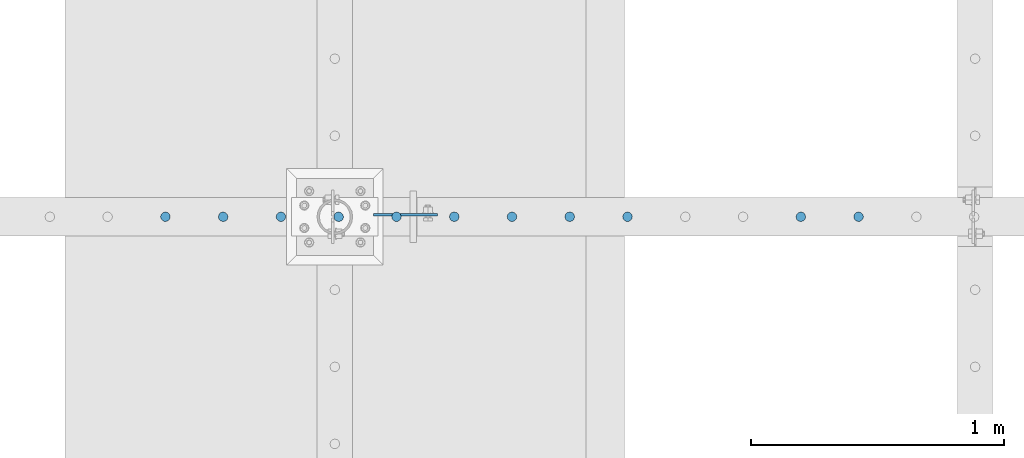
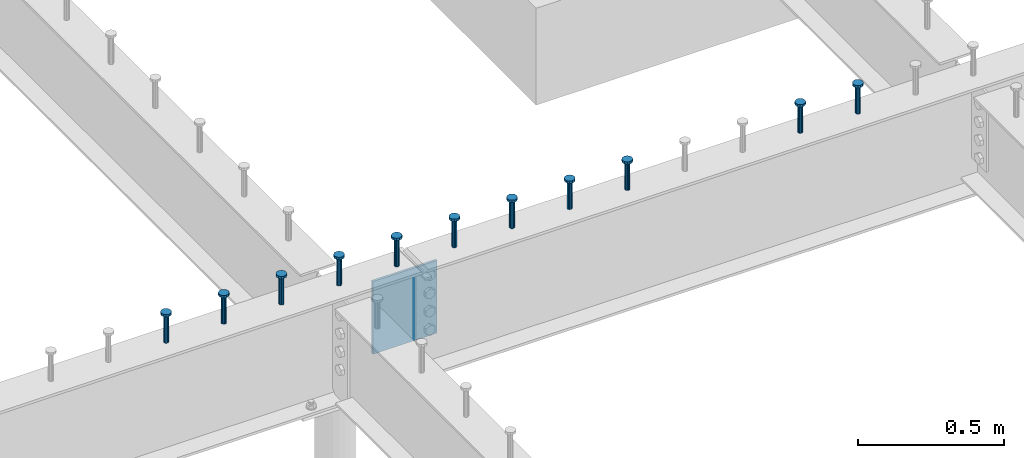
# One storey, part 190 of 975: 12 columns.
"""IFC2X3 building model written with IfcOpenShell, lengths in millimetres."""

from ifc_helpers import new_model, si_unit, frame, origin_with_axes, place, context, subcontext, project, spatial, faceted_brep, material, type_object, element, save


model = new_model("IFC2X3")

# Units and contexts
model_context = context("Model", 3, precision=1e-05, world=origin_with_axes())
body_context = subcontext(model_context, "Body", "Model", "MODEL_VIEW")
ifc_project = project(units=[si_unit("LENGTHUNIT", "METRE", prefix="MILLI"), si_unit("AREAUNIT", "SQUARE_METRE"), si_unit("VOLUMEUNIT", "CUBIC_METRE"), si_unit("MASSUNIT", "GRAM", prefix="KILO"), si_unit("TIMEUNIT", "SECOND"), si_unit("PLANEANGLEUNIT", "RADIAN"), si_unit("SOLIDANGLEUNIT", "STERADIAN"), si_unit("THERMODYNAMICTEMPERATUREUNIT", "DEGREE_CELSIUS"), si_unit("LUMINOUSINTENSITYUNIT", "LUMEN")], contexts=[model_context])

# Site, building, storey
site_placement = place(None, origin_with_axes())
site = spatial("IfcSite", under=ifc_project, at=site_placement, CompositionType="ELEMENT")
building_placement = place(site_placement, origin_with_axes())
building = spatial("IfcBuilding", under=site, at=building_placement, Name="Undefined", CompositionType="ELEMENT")
storey_placement = place(building_placement, origin_with_axes())
storey = spatial("IfcBuildingStorey", under=building, at=storey_placement, Name="Undefined", CompositionType="ELEMENT", Elevation=0.0)

# Columns
ifc_material_1 = material(Name="STEEL/A108")
column_type_1 = type_object("IfcColumnType", Name="STUD_3/4-DIA", PredefinedType="NOTDEFINED")
column_1_placement = place(storey_placement, frame((15560.1459584101, 13392.15, 3937.0), z_axis=(0.0, 1.0, 0.0), x_axis=(0.0, 0.0, 1.0)))
element("IfcColumn", 1, at=column_1_placement, inside=storey, type_object=column_type_1, material=ifc_material_1, ObjectType="STUD_3/4-DIA", context=body_context, shape_type="Brep", body=[
    faceted_brep([(0.0, -9.52000045776367, 0.0), (0.0, -8.25, -4.76000022888184), (115.57, -8.25, -4.76000022888184), (115.57, -9.52000045776367, 0.0), (0.0, -4.76000022888184, -8.25), (115.57, -4.76000022888184, -8.25), (0.0, 0.0, -9.52000045776367), (115.57, 0.0, -9.52000045776367), (0.0, 4.76000022888184, -8.25), (115.57, 4.76000022888184, -8.25), (0.0, 8.25, -4.76000022888184), (115.57, 8.25, -4.76000022888184), (0.0, 9.52000045776367, 0.0), (115.57, 9.52000045776367, 0.0), (0.0, 8.25, 4.76000022888184), (115.57, 8.25, 4.76000022888184), (0.0, 4.76000022888184, 8.25), (115.57, 4.76000022888184, 8.25), (0.0, 0.0, 9.52000045776367), (115.57, 0.0, 9.52000045776367), (0.0, -4.76000022888184, 8.25), (115.57, -4.76000022888184, 8.25), (0.0, -8.25, 4.76000022888184), (115.57, -8.25, 4.76000022888184), (116.84, -16.5, -9.52000045776367), (116.84, -19.0499992370605, 0.0), (116.84, -9.52000045776367, -16.5), (116.84, 0.0, -19.0499992370605), (116.84, 9.52000045776367, -16.5), (116.84, 16.5, -9.52000045776367), (116.84, 19.0499992370605, 0.0), (116.84, 16.5, 9.52000045776367), (116.84, 9.52000045776367, 16.5), (116.84, 0.0, 19.0499992370605), (116.84, -9.52000045776367, 16.5), (116.84, -16.5, 9.52000045776367), (127.0, -16.5, -9.52000045776367), (127.0, -19.0499992370605, 0.0), (127.0, -9.52000045776367, -16.5), (127.0, 0.0, -19.0499992370605), (127.0, 9.52000045776367, -16.5), (127.0, 16.5, -9.52000045776367), (127.0, 19.0499992370605, 0.0), (127.0, 16.5, 9.52000045776367), (127.0, 9.52000045776367, 16.5), (127.0, 0.0, 19.0499992370605), (127.0, -9.52000045776367, 16.5), (127.0, -16.5, 9.52000045776367)], [[[0, 1, 2, 3]], [[1, 4, 5, 2]], [[4, 6, 7, 5]], [[6, 8, 9, 7]], [[8, 10, 11, 9]], [[10, 12, 13, 11]], [[12, 14, 15, 13]], [[14, 16, 17, 15]], [[16, 18, 19, 17]], [[18, 20, 21, 19]], [[20, 22, 23, 21]], [[22, 0, 3, 23]], [[22, 20, 18, 16, 14, 12, 10, 8, 6, 4, 1, 0]], [[3, 2, 24, 25]], [[2, 5, 26, 24]], [[5, 7, 27, 26]], [[7, 9, 28, 27]], [[9, 11, 29, 28]], [[11, 13, 30, 29]], [[13, 15, 31, 30]], [[15, 17, 32, 31]], [[17, 19, 33, 32]], [[19, 21, 34, 33]], [[21, 23, 35, 34]], [[23, 3, 25, 35]], [[25, 24, 36, 37]], [[24, 26, 38, 36]], [[26, 27, 39, 38]], [[27, 28, 40, 39]], [[28, 29, 41, 40]], [[29, 30, 42, 41]], [[30, 31, 43, 42]], [[31, 32, 44, 43]], [[32, 33, 45, 44]], [[33, 34, 46, 45]], [[34, 35, 47, 46]], [[35, 25, 37, 47]], [[38, 39, 40, 41, 42, 43, 44, 45, 46, 47, 37, 36]]]),
])
column_2_placement = place(storey_placement, frame((15331.5459584101, 13392.15, 3937.0), z_axis=(0.0, 1.0, 0.0), x_axis=(0.0, 0.0, 1.0)))
element("IfcColumn", 2, at=column_2_placement, inside=storey, type_object=column_type_1, material=ifc_material_1, ObjectType="STUD_3/4-DIA", context=body_context, shape_type="Brep", body=[
    faceted_brep([(0.0, -9.52000045776367, 0.0), (0.0, -8.25, -4.76000022888184), (115.57, -8.25, -4.76000022888184), (115.57, -9.52000045776367, 0.0), (0.0, -4.76000022888184, -8.25), (115.57, -4.76000022888184, -8.25), (0.0, 0.0, -9.52000045776367), (115.57, 0.0, -9.52000045776367), (0.0, 4.76000022888184, -8.25), (115.57, 4.76000022888184, -8.25), (0.0, 8.25, -4.76000022888184), (115.57, 8.25, -4.76000022888184), (0.0, 9.52000045776367, 0.0), (115.57, 9.52000045776367, 0.0), (0.0, 8.25, 4.76000022888184), (115.57, 8.25, 4.76000022888184), (0.0, 4.76000022888184, 8.25), (115.57, 4.76000022888184, 8.25), (0.0, 0.0, 9.52000045776367), (115.57, 0.0, 9.52000045776367), (0.0, -4.76000022888184, 8.25), (115.57, -4.76000022888184, 8.25), (0.0, -8.25, 4.76000022888184), (115.57, -8.25, 4.76000022888184), (116.84, -16.5, -9.52000045776367), (116.84, -19.0499992370605, 0.0), (116.84, -9.52000045776367, -16.5), (116.84, 0.0, -19.0499992370605), (116.84, 9.52000045776367, -16.5), (116.84, 16.5, -9.52000045776367), (116.84, 19.0499992370605, 0.0), (116.84, 16.5, 9.52000045776367), (116.84, 9.52000045776367, 16.5), (116.84, 0.0, 19.0499992370605), (116.84, -9.52000045776367, 16.5), (116.84, -16.5, 9.52000045776367), (127.0, -16.5, -9.52000045776367), (127.0, -19.0499992370605, 0.0), (127.0, -9.52000045776367, -16.5), (127.0, 0.0, -19.0499992370605), (127.0, 9.52000045776367, -16.5), (127.0, 16.5, -9.52000045776367), (127.0, 19.0499992370605, 0.0), (127.0, 16.5, 9.52000045776367), (127.0, 9.52000045776367, 16.5), (127.0, 0.0, 19.0499992370605), (127.0, -9.52000045776367, 16.5), (127.0, -16.5, 9.52000045776367)], [[[0, 1, 2, 3]], [[1, 4, 5, 2]], [[4, 6, 7, 5]], [[6, 8, 9, 7]], [[8, 10, 11, 9]], [[10, 12, 13, 11]], [[12, 14, 15, 13]], [[14, 16, 17, 15]], [[16, 18, 19, 17]], [[18, 20, 21, 19]], [[20, 22, 23, 21]], [[22, 0, 3, 23]], [[22, 20, 18, 16, 14, 12, 10, 8, 6, 4, 1, 0]], [[3, 2, 24, 25]], [[2, 5, 26, 24]], [[5, 7, 27, 26]], [[7, 9, 28, 27]], [[9, 11, 29, 28]], [[11, 13, 30, 29]], [[13, 15, 31, 30]], [[15, 17, 32, 31]], [[17, 19, 33, 32]], [[19, 21, 34, 33]], [[21, 23, 35, 34]], [[23, 3, 25, 35]], [[25, 24, 36, 37]], [[24, 26, 38, 36]], [[26, 27, 39, 38]], [[27, 28, 40, 39]], [[28, 29, 41, 40]], [[29, 30, 42, 41]], [[30, 31, 43, 42]], [[31, 32, 44, 43]], [[32, 33, 45, 44]], [[33, 34, 46, 45]], [[34, 35, 47, 46]], [[35, 25, 37, 47]], [[38, 39, 40, 41, 42, 43, 44, 45, 46, 47, 37, 36]]]),
])
column_3_placement = place(storey_placement, frame((14645.7459584101, 13392.15, 3937.0), z_axis=(0.0, 1.0, 0.0), x_axis=(0.0, 0.0, 1.0)))
element("IfcColumn", 3, at=column_3_placement, inside=storey, type_object=column_type_1, material=ifc_material_1, ObjectType="STUD_3/4-DIA", context=body_context, shape_type="Brep", body=[
    faceted_brep([(0.0, -9.52000045776367, 0.0), (0.0, -8.25, -4.76000022888184), (115.57, -8.25, -4.76000022888184), (115.57, -9.52000045776367, 0.0), (0.0, -4.76000022888184, -8.25), (115.57, -4.76000022888184, -8.25), (0.0, 0.0, -9.52000045776367), (115.57, 0.0, -9.52000045776367), (0.0, 4.76000022888184, -8.25), (115.57, 4.76000022888184, -8.25), (0.0, 8.25, -4.76000022888184), (115.57, 8.25, -4.76000022888184), (0.0, 9.52000045776367, 0.0), (115.57, 9.52000045776367, 0.0), (0.0, 8.25, 4.76000022888184), (115.57, 8.25, 4.76000022888184), (0.0, 4.76000022888184, 8.25), (115.57, 4.76000022888184, 8.25), (0.0, 0.0, 9.52000045776367), (115.57, 0.0, 9.52000045776367), (0.0, -4.76000022888184, 8.25), (115.57, -4.76000022888184, 8.25), (0.0, -8.25, 4.76000022888184), (115.57, -8.25, 4.76000022888184), (116.84, -16.5, -9.52000045776367), (116.84, -19.0499992370605, 0.0), (116.84, -9.52000045776367, -16.5), (116.84, 0.0, -19.0499992370605), (116.84, 9.52000045776367, -16.5), (116.84, 16.5, -9.52000045776367), (116.84, 19.0499992370605, 0.0), (116.84, 16.5, 9.52000045776367), (116.84, 9.52000045776367, 16.5), (116.84, 0.0, 19.0499992370605), (116.84, -9.52000045776367, 16.5), (116.84, -16.5, 9.52000045776367), (127.0, -16.5, -9.52000045776367), (127.0, -19.0499992370605, 0.0), (127.0, -9.52000045776367, -16.5), (127.0, 0.0, -19.0499992370605), (127.0, 9.52000045776367, -16.5), (127.0, 16.5, -9.52000045776367), (127.0, 19.0499992370605, 0.0), (127.0, 16.5, 9.52000045776367), (127.0, 9.52000045776367, 16.5), (127.0, 0.0, 19.0499992370605), (127.0, -9.52000045776367, 16.5), (127.0, -16.5, 9.52000045776367)], [[[0, 1, 2, 3]], [[1, 4, 5, 2]], [[4, 6, 7, 5]], [[6, 8, 9, 7]], [[8, 10, 11, 9]], [[10, 12, 13, 11]], [[12, 14, 15, 13]], [[14, 16, 17, 15]], [[16, 18, 19, 17]], [[18, 20, 21, 19]], [[20, 22, 23, 21]], [[22, 0, 3, 23]], [[22, 20, 18, 16, 14, 12, 10, 8, 6, 4, 1, 0]], [[3, 2, 24, 25]], [[2, 5, 26, 24]], [[5, 7, 27, 26]], [[7, 9, 28, 27]], [[9, 11, 29, 28]], [[11, 13, 30, 29]], [[13, 15, 31, 30]], [[15, 17, 32, 31]], [[17, 19, 33, 32]], [[19, 21, 34, 33]], [[21, 23, 35, 34]], [[23, 3, 25, 35]], [[25, 24, 36, 37]], [[24, 26, 38, 36]], [[26, 27, 39, 38]], [[27, 28, 40, 39]], [[28, 29, 41, 40]], [[29, 30, 42, 41]], [[30, 31, 43, 42]], [[31, 32, 44, 43]], [[32, 33, 45, 44]], [[33, 34, 46, 45]], [[34, 35, 47, 46]], [[35, 25, 37, 47]], [[38, 39, 40, 41, 42, 43, 44, 45, 46, 47, 37, 36]]]),
])
column_4_placement = place(storey_placement, frame((14417.1459584101, 13392.15, 3937.0), z_axis=(0.0, 1.0, 0.0), x_axis=(0.0, 0.0, 1.0)))
element("IfcColumn", 4, at=column_4_placement, inside=storey, type_object=column_type_1, material=ifc_material_1, ObjectType="STUD_3/4-DIA", context=body_context, shape_type="Brep", body=[
    faceted_brep([(0.0, -9.52000045776367, 0.0), (0.0, -8.25, -4.76000022888184), (115.57, -8.25, -4.76000022888184), (115.57, -9.52000045776367, 0.0), (0.0, -4.76000022888184, -8.25), (115.57, -4.76000022888184, -8.25), (0.0, 0.0, -9.52000045776367), (115.57, 0.0, -9.52000045776367), (0.0, 4.76000022888184, -8.25), (115.57, 4.76000022888184, -8.25), (0.0, 8.25, -4.76000022888184), (115.57, 8.25, -4.76000022888184), (0.0, 9.52000045776367, 0.0), (115.57, 9.52000045776367, 0.0), (0.0, 8.25, 4.76000022888184), (115.57, 8.25, 4.76000022888184), (0.0, 4.76000022888184, 8.25), (115.57, 4.76000022888184, 8.25), (0.0, 0.0, 9.52000045776367), (115.57, 0.0, 9.52000045776367), (0.0, -4.76000022888184, 8.25), (115.57, -4.76000022888184, 8.25), (0.0, -8.25, 4.76000022888184), (115.57, -8.25, 4.76000022888184), (116.84, -16.5, -9.52000045776367), (116.84, -19.0499992370605, 0.0), (116.84, -9.52000045776367, -16.5), (116.84, 0.0, -19.0499992370605), (116.84, 9.52000045776367, -16.5), (116.84, 16.5, -9.52000045776367), (116.84, 19.0499992370605, 0.0), (116.84, 16.5, 9.52000045776367), (116.84, 9.52000045776367, 16.5), (116.84, 0.0, 19.0499992370605), (116.84, -9.52000045776367, 16.5), (116.84, -16.5, 9.52000045776367), (127.0, -16.5, -9.52000045776367), (127.0, -19.0499992370605, 0.0), (127.0, -9.52000045776367, -16.5), (127.0, 0.0, -19.0499992370605), (127.0, 9.52000045776367, -16.5), (127.0, 16.5, -9.52000045776367), (127.0, 19.0499992370605, 0.0), (127.0, 16.5, 9.52000045776367), (127.0, 9.52000045776367, 16.5), (127.0, 0.0, 19.0499992370605), (127.0, -9.52000045776367, 16.5), (127.0, -16.5, 9.52000045776367)], [[[0, 1, 2, 3]], [[1, 4, 5, 2]], [[4, 6, 7, 5]], [[6, 8, 9, 7]], [[8, 10, 11, 9]], [[10, 12, 13, 11]], [[12, 14, 15, 13]], [[14, 16, 17, 15]], [[16, 18, 19, 17]], [[18, 20, 21, 19]], [[20, 22, 23, 21]], [[22, 0, 3, 23]], [[22, 20, 18, 16, 14, 12, 10, 8, 6, 4, 1, 0]], [[3, 2, 24, 25]], [[2, 5, 26, 24]], [[5, 7, 27, 26]], [[7, 9, 28, 27]], [[9, 11, 29, 28]], [[11, 13, 30, 29]], [[13, 15, 31, 30]], [[15, 17, 32, 31]], [[17, 19, 33, 32]], [[19, 21, 34, 33]], [[21, 23, 35, 34]], [[23, 3, 25, 35]], [[25, 24, 36, 37]], [[24, 26, 38, 36]], [[26, 27, 39, 38]], [[27, 28, 40, 39]], [[28, 29, 41, 40]], [[29, 30, 42, 41]], [[30, 31, 43, 42]], [[31, 32, 44, 43]], [[32, 33, 45, 44]], [[33, 34, 46, 45]], [[34, 35, 47, 46]], [[35, 25, 37, 47]], [[38, 39, 40, 41, 42, 43, 44, 45, 46, 47, 37, 36]]]),
])
column_5_placement = place(storey_placement, frame((14188.5459584101, 13392.15, 3937.0), z_axis=(0.0, 1.0, 0.0), x_axis=(0.0, 0.0, 1.0)))
element("IfcColumn", 5, at=column_5_placement, inside=storey, type_object=column_type_1, material=ifc_material_1, ObjectType="STUD_3/4-DIA", context=body_context, shape_type="Brep", body=[
    faceted_brep([(0.0, -9.52000045776367, 0.0), (0.0, -8.25, -4.76000022888184), (115.57, -8.25, -4.76000022888184), (115.57, -9.52000045776367, 0.0), (0.0, -4.76000022888184, -8.25), (115.57, -4.76000022888184, -8.25), (0.0, 0.0, -9.52000045776367), (115.57, 0.0, -9.52000045776367), (0.0, 4.76000022888184, -8.25), (115.57, 4.76000022888184, -8.25), (0.0, 8.25, -4.76000022888184), (115.57, 8.25, -4.76000022888184), (0.0, 9.52000045776367, 0.0), (115.57, 9.52000045776367, 0.0), (0.0, 8.25, 4.76000022888184), (115.57, 8.25, 4.76000022888184), (0.0, 4.76000022888184, 8.25), (115.57, 4.76000022888184, 8.25), (0.0, 0.0, 9.52000045776367), (115.57, 0.0, 9.52000045776367), (0.0, -4.76000022888184, 8.25), (115.57, -4.76000022888184, 8.25), (0.0, -8.25, 4.76000022888184), (115.57, -8.25, 4.76000022888184), (116.84, -16.5, -9.52000045776367), (116.84, -19.0499992370605, 0.0), (116.84, -9.52000045776367, -16.5), (116.84, 0.0, -19.0499992370605), (116.84, 9.52000045776367, -16.5), (116.84, 16.5, -9.52000045776367), (116.84, 19.0499992370605, 0.0), (116.84, 16.5, 9.52000045776367), (116.84, 9.52000045776367, 16.5), (116.84, 0.0, 19.0499992370605), (116.84, -9.52000045776367, 16.5), (116.84, -16.5, 9.52000045776367), (127.0, -16.5, -9.52000045776367), (127.0, -19.0499992370605, 0.0), (127.0, -9.52000045776367, -16.5), (127.0, 0.0, -19.0499992370605), (127.0, 9.52000045776367, -16.5), (127.0, 16.5, -9.52000045776367), (127.0, 19.0499992370605, 0.0), (127.0, 16.5, 9.52000045776367), (127.0, 9.52000045776367, 16.5), (127.0, 0.0, 19.0499992370605), (127.0, -9.52000045776367, 16.5), (127.0, -16.5, 9.52000045776367)], [[[0, 1, 2, 3]], [[1, 4, 5, 2]], [[4, 6, 7, 5]], [[6, 8, 9, 7]], [[8, 10, 11, 9]], [[10, 12, 13, 11]], [[12, 14, 15, 13]], [[14, 16, 17, 15]], [[16, 18, 19, 17]], [[18, 20, 21, 19]], [[20, 22, 23, 21]], [[22, 0, 3, 23]], [[22, 20, 18, 16, 14, 12, 10, 8, 6, 4, 1, 0]], [[3, 2, 24, 25]], [[2, 5, 26, 24]], [[5, 7, 27, 26]], [[7, 9, 28, 27]], [[9, 11, 29, 28]], [[11, 13, 30, 29]], [[13, 15, 31, 30]], [[15, 17, 32, 31]], [[17, 19, 33, 32]], [[19, 21, 34, 33]], [[21, 23, 35, 34]], [[23, 3, 25, 35]], [[25, 24, 36, 37]], [[24, 26, 38, 36]], [[26, 27, 39, 38]], [[27, 28, 40, 39]], [[28, 29, 41, 40]], [[29, 30, 42, 41]], [[30, 31, 43, 42]], [[31, 32, 44, 43]], [[32, 33, 45, 44]], [[33, 34, 46, 45]], [[34, 35, 47, 46]], [[35, 25, 37, 47]], [[38, 39, 40, 41, 42, 43, 44, 45, 46, 47, 37, 36]]]),
])
column_6_placement = place(storey_placement, frame((13959.9459584101, 13392.15, 3937.0), z_axis=(0.0, 1.0, 0.0), x_axis=(0.0, 0.0, 1.0)))
element("IfcColumn", 6, at=column_6_placement, inside=storey, type_object=column_type_1, material=ifc_material_1, ObjectType="STUD_3/4-DIA", context=body_context, shape_type="Brep", body=[
    faceted_brep([(0.0, -9.52000045776367, 0.0), (0.0, -8.25, -4.76000022888184), (115.57, -8.25, -4.76000022888184), (115.57, -9.52000045776367, 0.0), (0.0, -4.76000022888184, -8.25), (115.57, -4.76000022888184, -8.25), (0.0, 0.0, -9.52000045776367), (115.57, 0.0, -9.52000045776367), (0.0, 4.76000022888184, -8.25), (115.57, 4.76000022888184, -8.25), (0.0, 8.25, -4.76000022888184), (115.57, 8.25, -4.76000022888184), (0.0, 9.52000045776367, 0.0), (115.57, 9.52000045776367, 0.0), (0.0, 8.25, 4.76000022888184), (115.57, 8.25, 4.76000022888184), (0.0, 4.76000022888184, 8.25), (115.57, 4.76000022888184, 8.25), (0.0, 0.0, 9.52000045776367), (115.57, 0.0, 9.52000045776367), (0.0, -4.76000022888184, 8.25), (115.57, -4.76000022888184, 8.25), (0.0, -8.25, 4.76000022888184), (115.57, -8.25, 4.76000022888184), (116.84, -16.5, -9.52000045776367), (116.84, -19.0499992370605, 0.0), (116.84, -9.52000045776367, -16.5), (116.84, 0.0, -19.0499992370605), (116.84, 9.52000045776367, -16.5), (116.84, 16.5, -9.52000045776367), (116.84, 19.0499992370605, 0.0), (116.84, 16.5, 9.52000045776367), (116.84, 9.52000045776367, 16.5), (116.84, 0.0, 19.0499992370605), (116.84, -9.52000045776367, 16.5), (116.84, -16.5, 9.52000045776367), (127.0, -16.5, -9.52000045776367), (127.0, -19.0499992370605, 0.0), (127.0, -9.52000045776367, -16.5), (127.0, 0.0, -19.0499992370605), (127.0, 9.52000045776367, -16.5), (127.0, 16.5, -9.52000045776367), (127.0, 19.0499992370605, 0.0), (127.0, 16.5, 9.52000045776367), (127.0, 9.52000045776367, 16.5), (127.0, 0.0, 19.0499992370605), (127.0, -9.52000045776367, 16.5), (127.0, -16.5, 9.52000045776367)], [[[0, 1, 2, 3]], [[1, 4, 5, 2]], [[4, 6, 7, 5]], [[6, 8, 9, 7]], [[8, 10, 11, 9]], [[10, 12, 13, 11]], [[12, 14, 15, 13]], [[14, 16, 17, 15]], [[16, 18, 19, 17]], [[18, 20, 21, 19]], [[20, 22, 23, 21]], [[22, 0, 3, 23]], [[22, 20, 18, 16, 14, 12, 10, 8, 6, 4, 1, 0]], [[3, 2, 24, 25]], [[2, 5, 26, 24]], [[5, 7, 27, 26]], [[7, 9, 28, 27]], [[9, 11, 29, 28]], [[11, 13, 30, 29]], [[13, 15, 31, 30]], [[15, 17, 32, 31]], [[17, 19, 33, 32]], [[19, 21, 34, 33]], [[21, 23, 35, 34]], [[23, 3, 25, 35]], [[25, 24, 36, 37]], [[24, 26, 38, 36]], [[26, 27, 39, 38]], [[27, 28, 40, 39]], [[28, 29, 41, 40]], [[29, 30, 42, 41]], [[30, 31, 43, 42]], [[31, 32, 44, 43]], [[32, 33, 45, 44]], [[33, 34, 46, 45]], [[34, 35, 47, 46]], [[35, 25, 37, 47]], [[38, 39, 40, 41, 42, 43, 44, 45, 46, 47, 37, 36]]]),
])
column_7_placement = place(storey_placement, frame((13731.3459584101, 13392.15, 3937.0), z_axis=(0.0, 1.0, 0.0), x_axis=(0.0, 0.0, 1.0)))
element("IfcColumn", 7, at=column_7_placement, inside=storey, type_object=column_type_1, material=ifc_material_1, ObjectType="STUD_3/4-DIA", context=body_context, shape_type="Brep", body=[
    faceted_brep([(0.0, -9.52000045776367, 0.0), (0.0, -8.25, -4.76000022888184), (115.57, -8.25, -4.76000022888184), (115.57, -9.52000045776367, 0.0), (0.0, -4.76000022888184, -8.25), (115.57, -4.76000022888184, -8.25), (0.0, 0.0, -9.52000045776367), (115.57, 0.0, -9.52000045776367), (0.0, 4.76000022888184, -8.25), (115.57, 4.76000022888184, -8.25), (0.0, 8.25, -4.76000022888184), (115.57, 8.25, -4.76000022888184), (0.0, 9.52000045776367, 0.0), (115.57, 9.52000045776367, 0.0), (0.0, 8.25, 4.76000022888184), (115.57, 8.25, 4.76000022888184), (0.0, 4.76000022888184, 8.25), (115.57, 4.76000022888184, 8.25), (0.0, 0.0, 9.52000045776367), (115.57, 0.0, 9.52000045776367), (0.0, -4.76000022888184, 8.25), (115.57, -4.76000022888184, 8.25), (0.0, -8.25, 4.76000022888184), (115.57, -8.25, 4.76000022888184), (116.84, -16.5, -9.52000045776367), (116.84, -19.0499992370605, 0.0), (116.84, -9.52000045776367, -16.5), (116.84, 0.0, -19.0499992370605), (116.84, 9.52000045776367, -16.5), (116.84, 16.5, -9.52000045776367), (116.84, 19.0499992370605, 0.0), (116.84, 16.5, 9.52000045776367), (116.84, 9.52000045776367, 16.5), (116.84, 0.0, 19.0499992370605), (116.84, -9.52000045776367, 16.5), (116.84, -16.5, 9.52000045776367), (127.0, -16.5, -9.52000045776367), (127.0, -19.0499992370605, 0.0), (127.0, -9.52000045776367, -16.5), (127.0, 0.0, -19.0499992370605), (127.0, 9.52000045776367, -16.5), (127.0, 16.5, -9.52000045776367), (127.0, 19.0499992370605, 0.0), (127.0, 16.5, 9.52000045776367), (127.0, 9.52000045776367, 16.5), (127.0, 0.0, 19.0499992370605), (127.0, -9.52000045776367, 16.5), (127.0, -16.5, 9.52000045776367)], [[[0, 1, 2, 3]], [[1, 4, 5, 2]], [[4, 6, 7, 5]], [[6, 8, 9, 7]], [[8, 10, 11, 9]], [[10, 12, 13, 11]], [[12, 14, 15, 13]], [[14, 16, 17, 15]], [[16, 18, 19, 17]], [[18, 20, 21, 19]], [[20, 22, 23, 21]], [[22, 0, 3, 23]], [[22, 20, 18, 16, 14, 12, 10, 8, 6, 4, 1, 0]], [[3, 2, 24, 25]], [[2, 5, 26, 24]], [[5, 7, 27, 26]], [[7, 9, 28, 27]], [[9, 11, 29, 28]], [[11, 13, 30, 29]], [[13, 15, 31, 30]], [[15, 17, 32, 31]], [[17, 19, 33, 32]], [[19, 21, 34, 33]], [[21, 23, 35, 34]], [[23, 3, 25, 35]], [[25, 24, 36, 37]], [[24, 26, 38, 36]], [[26, 27, 39, 38]], [[27, 28, 40, 39]], [[28, 29, 41, 40]], [[29, 30, 42, 41]], [[30, 31, 43, 42]], [[31, 32, 44, 43]], [[32, 33, 45, 44]], [[33, 34, 46, 45]], [[34, 35, 47, 46]], [[35, 25, 37, 47]], [[38, 39, 40, 41, 42, 43, 44, 45, 46, 47, 37, 36]]]),
])
column_8_placement = place(storey_placement, frame((13502.7459584101, 13392.15, 3937.0), z_axis=(0.0, 1.0, 0.0), x_axis=(0.0, 0.0, 1.0)))
element("IfcColumn", 8, at=column_8_placement, inside=storey, type_object=column_type_1, material=ifc_material_1, ObjectType="STUD_3/4-DIA", context=body_context, shape_type="Brep", body=[
    faceted_brep([(0.0, -9.52000045776367, 0.0), (0.0, -8.25, -4.76000022888184), (115.57, -8.25, -4.76000022888184), (115.57, -9.52000045776367, 0.0), (0.0, -4.76000022888184, -8.25), (115.57, -4.76000022888184, -8.25), (0.0, 0.0, -9.52000045776367), (115.57, 0.0, -9.52000045776367), (0.0, 4.76000022888184, -8.25), (115.57, 4.76000022888184, -8.25), (0.0, 8.25, -4.76000022888184), (115.57, 8.25, -4.76000022888184), (0.0, 9.52000045776367, 0.0), (115.57, 9.52000045776367, 0.0), (0.0, 8.25, 4.76000022888184), (115.57, 8.25, 4.76000022888184), (0.0, 4.76000022888184, 8.25), (115.57, 4.76000022888184, 8.25), (0.0, 0.0, 9.52000045776367), (115.57, 0.0, 9.52000045776367), (0.0, -4.76000022888184, 8.25), (115.57, -4.76000022888184, 8.25), (0.0, -8.25, 4.76000022888184), (115.57, -8.25, 4.76000022888184), (116.84, -16.5, -9.52000045776367), (116.84, -19.0499992370605, 0.0), (116.84, -9.52000045776367, -16.5), (116.84, 0.0, -19.0499992370605), (116.84, 9.52000045776367, -16.5), (116.84, 16.5, -9.52000045776367), (116.84, 19.0499992370605, 0.0), (116.84, 16.5, 9.52000045776367), (116.84, 9.52000045776367, 16.5), (116.84, 0.0, 19.0499992370605), (116.84, -9.52000045776367, 16.5), (116.84, -16.5, 9.52000045776367), (127.0, -16.5, -9.52000045776367), (127.0, -19.0499992370605, 0.0), (127.0, -9.52000045776367, -16.5), (127.0, 0.0, -19.0499992370605), (127.0, 9.52000045776367, -16.5), (127.0, 16.5, -9.52000045776367), (127.0, 19.0499992370605, 0.0), (127.0, 16.5, 9.52000045776367), (127.0, 9.52000045776367, 16.5), (127.0, 0.0, 19.0499992370605), (127.0, -9.52000045776367, 16.5), (127.0, -16.5, 9.52000045776367)], [[[0, 1, 2, 3]], [[1, 4, 5, 2]], [[4, 6, 7, 5]], [[6, 8, 9, 7]], [[8, 10, 11, 9]], [[10, 12, 13, 11]], [[12, 14, 15, 13]], [[14, 16, 17, 15]], [[16, 18, 19, 17]], [[18, 20, 21, 19]], [[20, 22, 23, 21]], [[22, 0, 3, 23]], [[22, 20, 18, 16, 14, 12, 10, 8, 6, 4, 1, 0]], [[3, 2, 24, 25]], [[2, 5, 26, 24]], [[5, 7, 27, 26]], [[7, 9, 28, 27]], [[9, 11, 29, 28]], [[11, 13, 30, 29]], [[13, 15, 31, 30]], [[15, 17, 32, 31]], [[17, 19, 33, 32]], [[19, 21, 34, 33]], [[21, 23, 35, 34]], [[23, 3, 25, 35]], [[25, 24, 36, 37]], [[24, 26, 38, 36]], [[26, 27, 39, 38]], [[27, 28, 40, 39]], [[28, 29, 41, 40]], [[29, 30, 42, 41]], [[30, 31, 43, 42]], [[31, 32, 44, 43]], [[32, 33, 45, 44]], [[33, 34, 46, 45]], [[34, 35, 47, 46]], [[35, 25, 37, 47]], [[38, 39, 40, 41, 42, 43, 44, 45, 46, 47, 37, 36]]]),
])
column_9_placement = place(storey_placement, frame((13274.1459584101, 13392.15, 3937.0), z_axis=(0.0, 1.0, 0.0), x_axis=(0.0, 0.0, 1.0)))
element("IfcColumn", 9, at=column_9_placement, inside=storey, type_object=column_type_1, material=ifc_material_1, ObjectType="STUD_3/4-DIA", context=body_context, shape_type="Brep", body=[
    faceted_brep([(0.0, -9.52000045776367, 0.0), (0.0, -8.25, -4.76000022888184), (115.57, -8.25, -4.76000022888184), (115.57, -9.52000045776367, 0.0), (0.0, -4.76000022888184, -8.25), (115.57, -4.76000022888184, -8.25), (0.0, 0.0, -9.52000045776367), (115.57, 0.0, -9.52000045776367), (0.0, 4.76000022888184, -8.25), (115.57, 4.76000022888184, -8.25), (0.0, 8.25, -4.76000022888184), (115.57, 8.25, -4.76000022888184), (0.0, 9.52000045776367, 0.0), (115.57, 9.52000045776367, 0.0), (0.0, 8.25, 4.76000022888184), (115.57, 8.25, 4.76000022888184), (0.0, 4.76000022888184, 8.25), (115.57, 4.76000022888184, 8.25), (0.0, 0.0, 9.52000045776367), (115.57, 0.0, 9.52000045776367), (0.0, -4.76000022888184, 8.25), (115.57, -4.76000022888184, 8.25), (0.0, -8.25, 4.76000022888184), (115.57, -8.25, 4.76000022888184), (116.84, -16.5, -9.52000045776367), (116.84, -19.0499992370605, 0.0), (116.84, -9.52000045776367, -16.5), (116.84, 0.0, -19.0499992370605), (116.84, 9.52000045776367, -16.5), (116.84, 16.5, -9.52000045776367), (116.84, 19.0499992370605, 0.0), (116.84, 16.5, 9.52000045776367), (116.84, 9.52000045776367, 16.5), (116.84, 0.0, 19.0499992370605), (116.84, -9.52000045776367, 16.5), (116.84, -16.5, 9.52000045776367), (127.0, -16.5, -9.52000045776367), (127.0, -19.0499992370605, 0.0), (127.0, -9.52000045776367, -16.5), (127.0, 0.0, -19.0499992370605), (127.0, 9.52000045776367, -16.5), (127.0, 16.5, -9.52000045776367), (127.0, 19.0499992370605, 0.0), (127.0, 16.5, 9.52000045776367), (127.0, 9.52000045776367, 16.5), (127.0, 0.0, 19.0499992370605), (127.0, -9.52000045776367, 16.5), (127.0, -16.5, 9.52000045776367)], [[[0, 1, 2, 3]], [[1, 4, 5, 2]], [[4, 6, 7, 5]], [[6, 8, 9, 7]], [[8, 10, 11, 9]], [[10, 12, 13, 11]], [[12, 14, 15, 13]], [[14, 16, 17, 15]], [[16, 18, 19, 17]], [[18, 20, 21, 19]], [[20, 22, 23, 21]], [[22, 0, 3, 23]], [[22, 20, 18, 16, 14, 12, 10, 8, 6, 4, 1, 0]], [[3, 2, 24, 25]], [[2, 5, 26, 24]], [[5, 7, 27, 26]], [[7, 9, 28, 27]], [[9, 11, 29, 28]], [[11, 13, 30, 29]], [[13, 15, 31, 30]], [[15, 17, 32, 31]], [[17, 19, 33, 32]], [[19, 21, 34, 33]], [[21, 23, 35, 34]], [[23, 3, 25, 35]], [[25, 24, 36, 37]], [[24, 26, 38, 36]], [[26, 27, 39, 38]], [[27, 28, 40, 39]], [[28, 29, 41, 40]], [[29, 30, 42, 41]], [[30, 31, 43, 42]], [[31, 32, 44, 43]], [[32, 33, 45, 44]], [[33, 34, 46, 45]], [[34, 35, 47, 46]], [[35, 25, 37, 47]], [[38, 39, 40, 41, 42, 43, 44, 45, 46, 47, 37, 36]]]),
])
column_10_placement = place(storey_placement, frame((13045.5459584101, 13392.15, 3937.0), z_axis=(0.0, 1.0, 0.0), x_axis=(0.0, 0.0, 1.0)))
element("IfcColumn", 10, at=column_10_placement, inside=storey, type_object=column_type_1, material=ifc_material_1, ObjectType="STUD_3/4-DIA", context=body_context, shape_type="Brep", body=[
    faceted_brep([(0.0, -9.52000045776367, 0.0), (0.0, -8.25, -4.76000022888184), (115.57, -8.25, -4.76000022888184), (115.57, -9.52000045776367, 0.0), (0.0, -4.76000022888184, -8.25), (115.57, -4.76000022888184, -8.25), (0.0, 0.0, -9.52000045776367), (115.57, 0.0, -9.52000045776367), (0.0, 4.76000022888184, -8.25), (115.57, 4.76000022888184, -8.25), (0.0, 8.25, -4.76000022888184), (115.57, 8.25, -4.76000022888184), (0.0, 9.52000045776367, 0.0), (115.57, 9.52000045776367, 0.0), (0.0, 8.25, 4.76000022888184), (115.57, 8.25, 4.76000022888184), (0.0, 4.76000022888184, 8.25), (115.57, 4.76000022888184, 8.25), (0.0, 0.0, 9.52000045776367), (115.57, 0.0, 9.52000045776367), (0.0, -4.76000022888184, 8.25), (115.57, -4.76000022888184, 8.25), (0.0, -8.25, 4.76000022888184), (115.57, -8.25, 4.76000022888184), (116.84, -16.5, -9.52000045776367), (116.84, -19.0499992370605, 0.0), (116.84, -9.52000045776367, -16.5), (116.84, 0.0, -19.0499992370605), (116.84, 9.52000045776367, -16.5), (116.84, 16.5, -9.52000045776367), (116.84, 19.0499992370605, 0.0), (116.84, 16.5, 9.52000045776367), (116.84, 9.52000045776367, 16.5), (116.84, 0.0, 19.0499992370605), (116.84, -9.52000045776367, 16.5), (116.84, -16.5, 9.52000045776367), (127.0, -16.5, -9.52000045776367), (127.0, -19.0499992370605, 0.0), (127.0, -9.52000045776367, -16.5), (127.0, 0.0, -19.0499992370605), (127.0, 9.52000045776367, -16.5), (127.0, 16.5, -9.52000045776367), (127.0, 19.0499992370605, 0.0), (127.0, 16.5, 9.52000045776367), (127.0, 9.52000045776367, 16.5), (127.0, 0.0, 19.0499992370605), (127.0, -9.52000045776367, 16.5), (127.0, -16.5, 9.52000045776367)], [[[0, 1, 2, 3]], [[1, 4, 5, 2]], [[4, 6, 7, 5]], [[6, 8, 9, 7]], [[8, 10, 11, 9]], [[10, 12, 13, 11]], [[12, 14, 15, 13]], [[14, 16, 17, 15]], [[16, 18, 19, 17]], [[18, 20, 21, 19]], [[20, 22, 23, 21]], [[22, 0, 3, 23]], [[22, 20, 18, 16, 14, 12, 10, 8, 6, 4, 1, 0]], [[3, 2, 24, 25]], [[2, 5, 26, 24]], [[5, 7, 27, 26]], [[7, 9, 28, 27]], [[9, 11, 29, 28]], [[11, 13, 30, 29]], [[13, 15, 31, 30]], [[15, 17, 32, 31]], [[17, 19, 33, 32]], [[19, 21, 34, 33]], [[21, 23, 35, 34]], [[23, 3, 25, 35]], [[25, 24, 36, 37]], [[24, 26, 38, 36]], [[26, 27, 39, 38]], [[27, 28, 40, 39]], [[28, 29, 41, 40]], [[29, 30, 42, 41]], [[30, 31, 43, 42]], [[31, 32, 44, 43]], [[32, 33, 45, 44]], [[33, 34, 46, 45]], [[34, 35, 47, 46]], [[35, 25, 37, 47]], [[38, 39, 40, 41, 42, 43, 44, 45, 46, 47, 37, 36]]]),
])
column_11_placement = place(storey_placement, frame((12816.9459584101, 13392.15, 3937.0), z_axis=(0.0, 1.0, 0.0), x_axis=(0.0, 0.0, 1.0)))
element("IfcColumn", 11, at=column_11_placement, inside=storey, type_object=column_type_1, material=ifc_material_1, ObjectType="STUD_3/4-DIA", context=body_context, shape_type="Brep", body=[
    faceted_brep([(0.0, -9.52000045776367, 0.0), (0.0, -8.25, -4.76000022888184), (115.57, -8.25, -4.76000022888184), (115.57, -9.52000045776367, 0.0), (0.0, -4.76000022888184, -8.25), (115.57, -4.76000022888184, -8.25), (0.0, 0.0, -9.52000045776367), (115.57, 0.0, -9.52000045776367), (0.0, 4.76000022888184, -8.25), (115.57, 4.76000022888184, -8.25), (0.0, 8.25, -4.76000022888184), (115.57, 8.25, -4.76000022888184), (0.0, 9.52000045776367, 0.0), (115.57, 9.52000045776367, 0.0), (0.0, 8.25, 4.76000022888184), (115.57, 8.25, 4.76000022888184), (0.0, 4.76000022888184, 8.25), (115.57, 4.76000022888184, 8.25), (0.0, 0.0, 9.52000045776367), (115.57, 0.0, 9.52000045776367), (0.0, -4.76000022888184, 8.25), (115.57, -4.76000022888184, 8.25), (0.0, -8.25, 4.76000022888184), (115.57, -8.25, 4.76000022888184), (116.84, -16.5, -9.52000045776367), (116.84, -19.0499992370605, 0.0), (116.84, -9.52000045776367, -16.5), (116.84, 0.0, -19.0499992370605), (116.84, 9.52000045776367, -16.5), (116.84, 16.5, -9.52000045776367), (116.84, 19.0499992370605, 0.0), (116.84, 16.5, 9.52000045776367), (116.84, 9.52000045776367, 16.5), (116.84, 0.0, 19.0499992370605), (116.84, -9.52000045776367, 16.5), (116.84, -16.5, 9.52000045776367), (127.0, -16.5, -9.52000045776367), (127.0, -19.0499992370605, 0.0), (127.0, -9.52000045776367, -16.5), (127.0, 0.0, -19.0499992370605), (127.0, 9.52000045776367, -16.5), (127.0, 16.5, -9.52000045776367), (127.0, 19.0499992370605, 0.0), (127.0, 16.5, 9.52000045776367), (127.0, 9.52000045776367, 16.5), (127.0, 0.0, 19.0499992370605), (127.0, -9.52000045776367, 16.5), (127.0, -16.5, 9.52000045776367)], [[[0, 1, 2, 3]], [[1, 4, 5, 2]], [[4, 6, 7, 5]], [[6, 8, 9, 7]], [[8, 10, 11, 9]], [[10, 12, 13, 11]], [[12, 14, 15, 13]], [[14, 16, 17, 15]], [[16, 18, 19, 17]], [[18, 20, 21, 19]], [[20, 22, 23, 21]], [[22, 0, 3, 23]], [[22, 20, 18, 16, 14, 12, 10, 8, 6, 4, 1, 0]], [[3, 2, 24, 25]], [[2, 5, 26, 24]], [[5, 7, 27, 26]], [[7, 9, 28, 27]], [[9, 11, 29, 28]], [[11, 13, 30, 29]], [[13, 15, 31, 30]], [[15, 17, 32, 31]], [[17, 19, 33, 32]], [[19, 21, 34, 33]], [[21, 23, 35, 34]], [[23, 3, 25, 35]], [[25, 24, 36, 37]], [[24, 26, 38, 36]], [[26, 27, 39, 38]], [[27, 28, 40, 39]], [[28, 29, 41, 40]], [[29, 30, 42, 41]], [[30, 31, 43, 42]], [[31, 32, 44, 43]], [[32, 33, 45, 44]], [[33, 34, 46, 45]], [[34, 35, 47, 46]], [[35, 25, 37, 47]], [[38, 39, 40, 41, 42, 43, 44, 45, 46, 47, 37, 36]]]),
])
ifc_material_2 = material(Name="STEEL/A36")
column_type_2 = type_object("IfcColumnType", PredefinedType="NOTDEFINED")
column_12_placement = place(storey_placement, frame((13766.8, 13400.88125, 3594.1), z_axis=(-0.999999999999998, 6.90000001668524e-08, 0.0), x_axis=(0.0, 0.0, 1.0)))
element("IfcColumn", 12, at=column_12_placement, inside=storey, type_object=column_type_2, material=ifc_material_2, Name="PLATE", context=body_context, shape_type="Brep", body=[
    faceted_brep([(0.0, 4.76250000000073, -127.0), (2.26333322643768e-05, 4.76250000029177, 127.000000000276), (304.8, 4.76250000000073, 127.0), (304.8, 4.76250000000073, -127.0), (2.26333322643768e-05, -4.76249999968422, 127.000000000295), (304.8, -4.76250000000073, 127.0), (0.0, -4.76250000000073, -127.0), (304.8, -4.76250000000073, -127.0)], [[[0, 1, 2, 3]], [[1, 4, 5, 2]], [[4, 6, 7, 5]], [[6, 0, 3, 7]], [[5, 7, 3, 2]], [[6, 4, 1, 0]]]),
])

save(model, "model.ifc")
